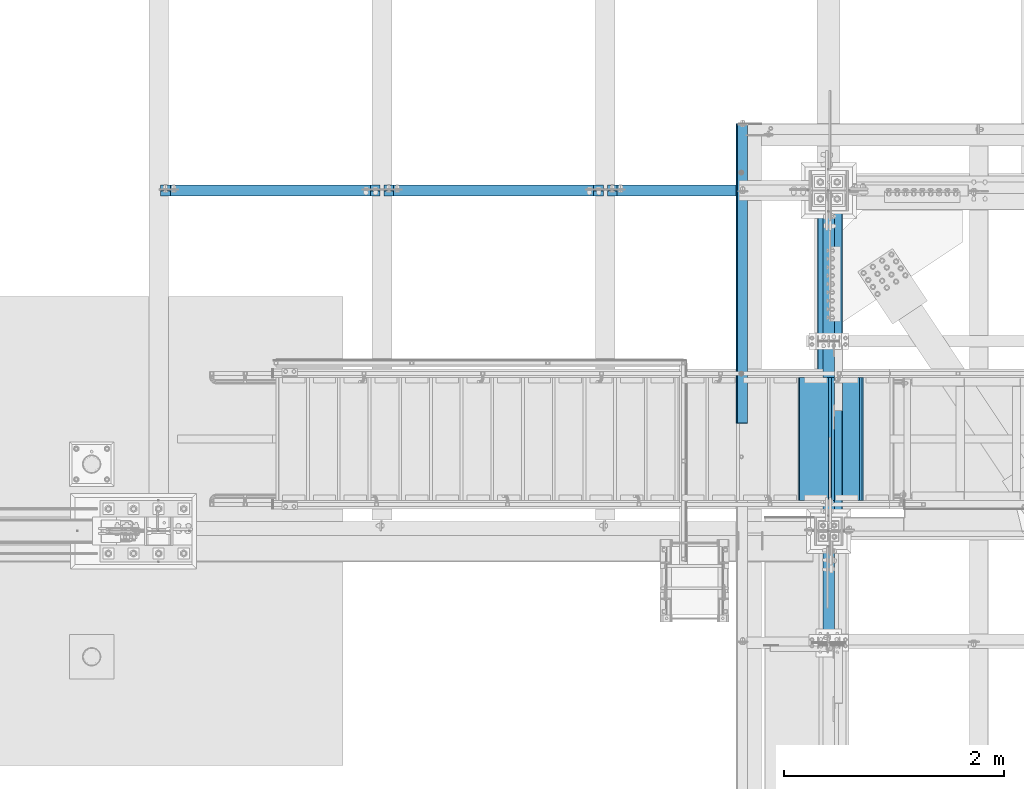
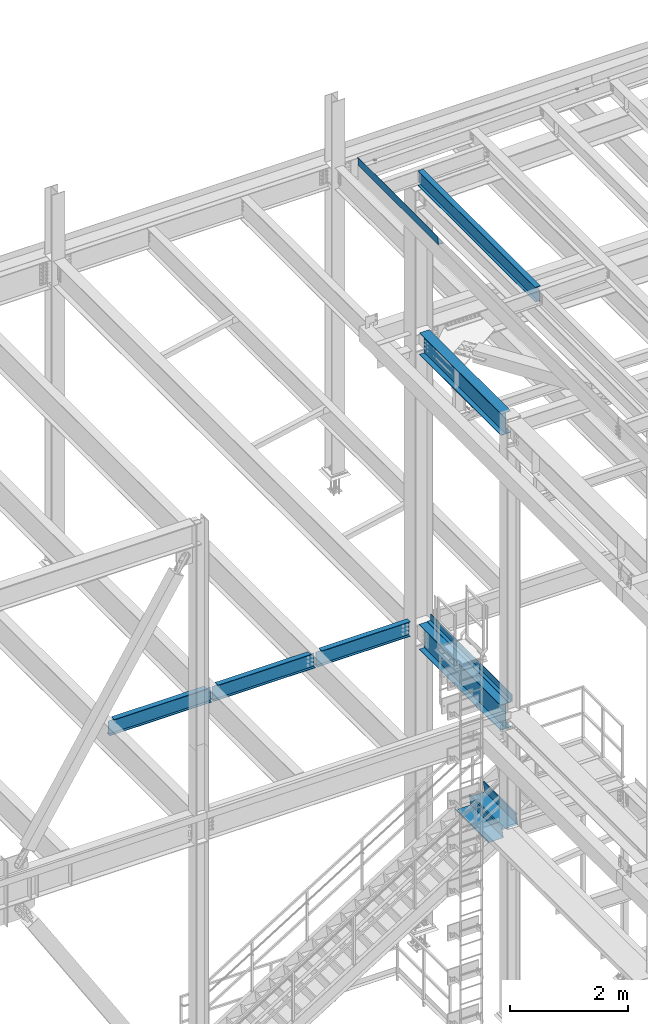
# One storey, part 1885 of 3843: 10 beams, 8 elements without a shape of their own.
"""IFC2X3 building model written with IfcOpenShell, lengths in millimetres."""

from ifc_helpers import new_model, si_unit, frame, origin_with_axes, place, context, subcontext, project, spatial, faceted_brep, material, type_object, element, aggregate, save


model = new_model("IFC2X3")

# Units and contexts
model_context = context("Model", 3, precision=1e-05, world=origin_with_axes())
body_context = subcontext(model_context, "Body", "Model", "MODEL_VIEW")
ifc_project = project(units=[si_unit("LENGTHUNIT", "METRE", prefix="MILLI"), si_unit("AREAUNIT", "SQUARE_METRE"), si_unit("VOLUMEUNIT", "CUBIC_METRE"), si_unit("MASSUNIT", "GRAM", prefix="KILO"), si_unit("TIMEUNIT", "SECOND"), si_unit("PLANEANGLEUNIT", "RADIAN"), si_unit("SOLIDANGLEUNIT", "STERADIAN"), si_unit("THERMODYNAMICTEMPERATUREUNIT", "DEGREE_CELSIUS"), si_unit("LUMINOUSINTENSITYUNIT", "LUMEN")], contexts=[model_context])

# Site, building, storey
site_placement = place(None, origin_with_axes())
site = spatial("IfcSite", under=ifc_project, at=site_placement, CompositionType="ELEMENT")
building_placement = place(site_placement, origin_with_axes())
building = spatial("IfcBuilding", under=site, at=building_placement, Name="Undefined", CompositionType="ELEMENT")
storey_placement = place(building_placement, origin_with_axes())
storey = spatial("IfcBuildingStorey", under=building, at=storey_placement, Name="Undefined", CompositionType="ELEMENT", Elevation=0.0)

# Assembly, beam
assembly_1_placement = place(storey_placement, origin_with_axes())
assembly_1 = element("IfcElementAssembly", 1, at=assembly_1_placement, inside=storey, Name="BEAM", AssemblyPlace="NOTDEFINED", PredefinedType="RIGID_FRAME")
ifc_material_1 = material(Name="STEEL/A36")
beam_type_1 = type_object("IfcBeamType", PredefinedType="NOTDEFINED")
beam_1_placement = place(assembly_1_placement, frame((35839.3101110584, 91460.6375000001, 45717.1843160679), z_axis=(0.0, -1.0, 0.0), x_axis=(-0.999776270257024, 0.0, -0.0211520550054595)))
beam_1 = element("IfcBeam", 2, at=beam_1_placement, type_object=beam_type_1, material=ifc_material_1, Name="BENT_PLATE", context=body_context, shape_type="Brep", body=[
    faceted_brep([(95.2499999981301, -3.17499999995925, 1360.48750004773), (98.4249999510357, -4.77521098218858e-08, 1363.66250000001), (7.27595761418343e-12, -4.77957655675709e-08, 1363.66250000001), (0.0, -3.17499999999563, 1360.48750004772), (95.249999998945, -161.924999996852, 1360.48750004773), (98.4249999518506, -161.924999996845, 1363.66250000001), (0.0, -3.17499999999563, -1363.66250000001), (95.2499999981301, -3.17499999995925, -1363.66250000001), (7.27595761418343e-12, 3.17499999998836, 1363.66250000001), (7.27595761418343e-12, 3.17499999998836, -1363.66250000001), (101.5999999981, 3.17500000003201, 1363.66250000001), (101.5999999981, 3.17500000003201, -1363.66250000001), (101.599999998929, -161.924999996831, 1363.66250000001), (101.599999998929, -161.924999996831, -1363.66250000001), (95.249999998945, -161.924999996852, -1363.66250000001)], [[[0, 1, 2, 3]], [[4, 5, 1, 0]], [[6, 7, 0, 3]], [[8, 9, 6, 3, 2]], [[9, 8, 10, 11]], [[11, 10, 12, 13]], [[5, 12, 10, 8, 2, 1]], [[7, 14, 4, 0]], [[7, 6, 9, 11, 13, 14]], [[14, 13, 12, 5, 4]]]),
])
aggregate(assembly_1, [beam_1])

# Assembly, beams
assembly_2_placement = place(storey_placement, origin_with_axes())
assembly_2 = element("IfcElementAssembly", 3, at=assembly_2_placement, inside=storey, Name="STAIR", AssemblyPlace="NOTDEFINED", PredefinedType="RIGID_FRAME")
ifc_material_2 = material(Name="STEEL/ASTM A1011")
beam_type_2 = type_object("IfcBeamType", PredefinedType="NOTDEFINED")
beam_2_placement = place(assembly_2_placement, frame((36880.8000000271, 89954.1000000435, 33961.8410714329), z_axis=(0.0, -1.0, 0.0), x_axis=(-1.0, 0.0, 0.0)))
beam_2 = element("IfcBeam", 4, at=beam_2_placement, type_object=beam_type_2, material=ifc_material_2, Name="TREAD", context=body_context, shape_type="Brep", body=[
    faceted_brep([(0.0, -1.58750000000146, -558.799999999999), (0.0, -1.58750000000146, 558.799999999999), (0.0, 1.58750000000146, 558.799999999999), (0.0, 1.58750000000146, -558.799999999999), (21.7283948539116, 1.58750000000146, 558.800000000003), (21.7283948539116, 1.58750000000146, -558.800000000003), (25.3999999999942, -1.58750000000146, -558.799999999999), (25.3999999999942, -1.58750000000146, 558.799999999999), (-11.0799384794227, 226.55892857143, 558.800000000003), (-11.0799384794227, 226.55892857143, -558.800000000003), (-7.40833333332557, 223.383928571428, -558.800000000003), (-7.40833333332557, 223.383928571428, 558.800000000003), (293.720061520566, 226.55892857143, 558.800000000003), (293.720061520566, 226.55892857143, -558.800000000003), (290.974498041134, 223.383928571428, -558.800000000003), (290.974498041134, 223.383928571428, 558.800000000003), (299.614357882056, 186.140896378427, 558.800000000003), (299.614357882056, 186.140896378427, -558.800000000003), (296.472590667174, 185.682721992918, 558.800000000003), (296.472590667174, 185.682721992918, -558.800000000003)], [[[0, 1, 2, 3]], [[3, 2, 4, 5]], [[1, 0, 6, 7]], [[5, 4, 8, 9]], [[7, 6, 10, 11]], [[9, 8, 12, 13]], [[11, 10, 14, 15]], [[13, 12, 16, 17]], [[12, 8, 4, 2, 1, 7, 11, 15, 18, 16]], [[15, 14, 19, 18]], [[14, 10, 6, 0, 3, 5, 9, 13, 17, 19]], [[18, 19, 17, 16]]]),
])
beam_3_placement = place(assembly_2_placement, frame((36601.4000000271, 89954.1000000435, 33787.6696428615), z_axis=(0.0, -1.0, 0.0), x_axis=(-1.0, 0.0, 0.0)))
beam_3 = element("IfcBeam", 5, at=beam_3_placement, type_object=beam_type_2, material=ifc_material_2, Name="TREAD", context=body_context, shape_type="Brep", body=[
    faceted_brep([(0.0, -1.58750000000146, -558.799999999999), (0.0, -1.58750000000146, 558.799999999999), (0.0, 1.58750000000146, 558.799999999999), (0.0, 1.58750000000146, -558.799999999999), (21.7283948539116, 1.58750000000146, 558.800000000003), (21.7283948539116, 1.58750000000146, -558.800000000003), (25.3999999999942, -1.58750000000146, -558.799999999999), (25.3999999999942, -1.58750000000146, 558.799999999999), (-11.0799384794227, 226.55892857143, 558.800000000003), (-11.0799384794227, 226.55892857143, -558.800000000003), (-7.40833333332557, 223.383928571428, -558.800000000003), (-7.40833333332557, 223.383928571428, 558.800000000003), (293.720061520566, 226.55892857143, 558.800000000003), (293.720061520566, 226.55892857143, -558.800000000003), (290.974498041134, 223.383928571428, -558.800000000003), (290.974498041134, 223.383928571428, 558.800000000003), (299.614357882056, 186.140896378427, 558.800000000003), (299.614357882056, 186.140896378427, -558.800000000003), (296.472590667174, 185.682721992918, 558.800000000003), (296.472590667174, 185.682721992918, -558.800000000003)], [[[0, 1, 2, 3]], [[3, 2, 4, 5]], [[1, 0, 6, 7]], [[5, 4, 8, 9]], [[7, 6, 10, 11]], [[9, 8, 12, 13]], [[11, 10, 14, 15]], [[13, 12, 16, 17]], [[12, 8, 4, 2, 1, 7, 11, 15, 18, 16]], [[15, 14, 19, 18]], [[14, 10, 6, 0, 3, 5, 9, 13, 17, 19]], [[18, 19, 17, 16]]]),
])
aggregate(assembly_2, [beam_2, beam_3])

# Assembly, beam
assembly_3_placement = place(storey_placement, origin_with_axes())
assembly_3 = element("IfcElementAssembly", 6, at=assembly_3_placement, inside=storey, Name="BEAM", AssemblyPlace="NOTDEFINED", PredefinedType="RIGID_FRAME")
ifc_material_3 = material(Name="STEEL/A992")
beam_type_3 = type_object("IfcBeamType", Name="W12X19", PredefinedType="NOTDEFINED")
beam_4_placement = place(assembly_3_placement, frame((36576.0000000053, 88099.9, 45575.6071293695), z_axis=(0.0, 0.0, 1.0), x_axis=(0.0, 1.0, 0.0)))
beam_4 = element("IfcBeam", 7, at=beam_4_placement, type_object=beam_type_3, material=ifc_material_3, Name="BEAM", ObjectType="W12X19", context=body_context, shape_type="Brep", body=[
    faceted_brep([(4048.125, -3.17500000000291, -144.462500000001), (4048.125, -50.8000000000029, -144.462500000001), (4048.125, -50.8000000000029, -153.987500000003), (4048.125, 50.8000000000029, -153.987500000003), (4048.125, 50.8000000000029, -144.462500000001), (4048.125, 3.17500000000291, -144.462500000001), (4048.125, 3.17500000000291, -141.287499808233), (4048.125, -3.17500000000291, -141.287499808233), (4049.09172992258, 3.17500000000291, -136.427420290187), (4049.09172992258, -3.17500000000291, -136.427420290187), (4051.84474382307, 3.17500000000291, -132.307243822033), (4051.84474382307, -3.17500000000291, -132.307243822033), (4055.96492029123, 3.17500000000291, -129.554229921559), (4055.96492029123, -3.17500000000291, -129.554229921559), (4060.82499980927, 3.17500000000291, -128.587499998968), (4060.82499980927, -3.17500000000291, -128.587499998968), (4098.925, -3.17500000000291, -128.587499998968), (4098.925, 3.17500000000291, -128.587499998968), (4048.125, 50.8000000000029, 144.462500000001), (4048.125, 3.17500000000291, 144.462500000001), (66.6750000000175, 3.17500000000291, 144.462500000001), (66.6750000000175, 50.8000000000029, 144.462500000001), (66.6750000000175, -3.17500000000291, -141.287499808226), (66.6750000000175, 3.17500000000291, -141.287499808226), (66.6750000000175, 3.17500000000291, -144.462500000001), (66.6750000000175, 50.8000000000029, -144.462500000001), (66.6750000000175, 50.8000000000029, -153.987500000003), (66.6750000000175, -50.8000000000029, -153.987500000003), (66.6750000000175, -50.8000000000029, -144.462500000001), (66.6750000000175, -3.17500000000291, -144.462500000001), (65.7082700774336, -3.17500000000291, -136.42742029018), (65.7082700774336, 3.17500000000291, -136.42742029018), (62.9552561769524, -3.17500000000291, -132.307243822026), (62.9552561769524, 3.17500000000291, -132.307243822026), (58.8350797087915, -3.17500000000291, -129.554229921552), (58.8350797087915, 3.17500000000291, -129.554229921552), (53.9750001907523, -3.17500000000291, -128.587499998961), (53.9750001907523, 3.17500000000291, -128.587499998961), (15.8750000000146, -3.17500000000291, -128.587499998961), (15.8750000000146, 3.17500000000291, -128.587499998961), (15.8750000000146, -3.17500000000291, 128.587500001042), (15.8750000000146, 3.17500000000291, 128.587500001042), (15.8750000000146, 3.17500000000291, 115.887500001612), (15.8750000000146, 3.17500000000291, -114.712499998386), (53.9750001907523, -3.17500000000291, 128.587500001042), (53.9750001907523, 3.17500000000291, 128.587500001042), (58.8350797087915, -3.17500000000291, 129.554229923633), (58.8350797087915, 3.17500000000291, 129.554229923633), (62.9552561769524, -3.17500000000291, 132.307243824107), (62.9552561769524, 3.17500000000291, 132.307243824107), (65.7082700774336, -3.17500000000291, 136.427420292261), (65.7082700774336, 3.17500000000291, 136.427420292261), (66.6750000000175, -3.17500000000291, 141.287499810307), (66.6750000000175, 3.17500000000291, 141.287499810307), (66.6750000000175, -50.8000000000029, 153.987500000003), (66.6750000000175, 50.8000000000029, 153.987500000003), (66.6750000000175, -3.17500000000291, 144.462500000001), (66.6750000000175, -50.8000000000029, 144.462500000001), (4048.125, -3.17500000000291, 144.462500000001), (4048.125, -50.8000000000029, 144.462500000001), (4048.125, -50.8000000000029, 153.987500000003), (4048.125, 50.8000000000029, 153.987500000003), (4048.125, -3.17500000000291, 141.2874998103), (4048.125, 3.17500000000291, 141.2874998103), (4049.09172992258, -3.17500000000291, 136.427420292253), (4049.09172992258, 3.17500000000291, 136.427420292253), (4051.84474382307, -3.17500000000291, 132.3072438241), (4051.84474382307, 3.17500000000291, 132.3072438241), (4055.96492029123, -3.17500000000291, 129.554229923626), (4055.96492029123, 3.17500000000291, 129.554229923626), (4060.82499980927, -3.17500000000291, 128.587500001035), (4060.82499980927, 3.17500000000291, 128.587500001035), (4098.925, -3.17500000000291, 128.587500001035), (4098.925, 3.17500000000291, 128.587500001035), (4098.925, 3.17500000000291, -114.712499998452), (4098.925, 3.17500000000291, 115.887500001547)], [[[0, 1, 2, 3, 4, 5, 6, 7]], [[7, 6, 8, 9]], [[9, 8, 10, 11]], [[11, 10, 12, 13]], [[13, 12, 14, 15]], [[16, 15, 14, 17]], [[18, 19, 20, 21]], [[22, 23, 24, 25, 26, 27, 28, 29]], [[30, 31, 23, 22]], [[32, 33, 31, 30]], [[34, 35, 33, 32]], [[36, 37, 35, 34]], [[38, 39, 37, 36]], [[40, 41, 42, 43, 39, 38]], [[44, 45, 41, 40]], [[46, 47, 45, 44]], [[48, 49, 47, 46]], [[50, 51, 49, 48]], [[52, 53, 51, 50]], [[54, 55, 21, 20, 53, 52, 56, 57]], [[58, 59, 57, 56]], [[59, 60, 54, 57]], [[60, 61, 55, 54]], [[61, 18, 21, 55]], [[60, 59, 58, 62, 63, 19, 18, 61]], [[64, 65, 63, 62]], [[66, 67, 65, 64]], [[68, 69, 67, 66]], [[70, 71, 69, 68]], [[72, 73, 71, 70]], [[74, 75, 73, 72, 16, 17]], [[33, 35, 37, 39, 43, 42, 41, 45, 47, 49, 51, 53, 20, 19, 63, 65, 67, 69, 71, 73, 75, 74, 17, 14, 12, 10, 8, 6, 5, 24, 23, 31]], [[5, 4, 25, 24]], [[4, 3, 26, 25]], [[3, 2, 27, 26]], [[2, 1, 28, 27]], [[1, 0, 29, 28]], [[0, 7, 9, 11, 13, 15, 16, 72, 70, 68, 66, 64, 62, 58, 56, 52, 50, 48, 46, 44, 40, 38, 36, 34, 32, 30, 22, 29]]]),
])
aggregate(assembly_3, [beam_4])

assembly_4_placement = place(storey_placement, origin_with_axes())
assembly_4 = element("IfcElementAssembly", 8, at=assembly_4_placement, inside=storey, Name="BEAM", AssemblyPlace="NOTDEFINED", PredefinedType="RIGID_FRAME")
beam_5_placement = place(assembly_4_placement, frame((30480.0, 92214.7, 36282.3125), z_axis=(0.0, 0.0, 1.0), x_axis=(1.0, 0.0, 0.0)))
beam_5 = element("IfcBeam", 9, at=beam_5_placement, type_object=beam_type_3, material=ifc_material_3, Name="BEAM", ObjectType="W12X19", context=body_context, shape_type="Brep", body=[
    faceted_brep([(1925.6375, -50.8000000000029, 153.987499991192), (1925.6375, -50.8000000000029, 144.462500000001), (1925.6375, -3.17500000000291, 144.462500000001), (1925.6375, -3.17500000000291, 141.287499809267), (1925.6375, 3.17500000000291, 141.287499809267), (1925.6375, 3.17500000000291, 144.462500000001), (1925.6375, 50.8000000000029, 144.462500000001), (1925.6375, 50.8000000000029, 153.987500000003), (1926.60422992258, -3.17500000000291, 136.42742029122), (1926.60422992258, 3.17500000000291, 136.42742029122), (1929.35724382306, -3.17500000000291, 132.307243823067), (1929.35724382306, 3.17500000000291, 132.307243823067), (1933.47742029122, -3.17500000000291, 129.554229922593), (1933.47742029122, 3.17500000000291, 129.554229922593), (1938.33749980926, -3.17500000000291, 128.587500000001), (1938.33749980926, 3.17500000000291, 128.587500000001), (2014.5375, -3.17500000000291, 128.587500000001), (2014.5375, 3.17500000000291, 128.587500000001), (106.362500000003, -50.8000000000029, 153.987499811003), (106.362500000003, 50.8000000000029, 153.987500000003), (106.362500000003, 50.8000000000029, 144.462500000001), (106.362500000003, 3.17500000000291, 144.462500000001), (106.362500000003, 3.17500000000291, 141.287499809267), (106.362500000003, -3.17500000000291, 141.287499809267), (106.362500000003, -3.17500000000291, 144.462500000001), (106.362500000003, -50.8000000000029, 144.462500000001), (105.395770077415, 3.17500000000291, 136.42742029122), (105.395770077415, -3.17500000000291, 136.42742029122), (102.642756176938, 3.17500000000291, 132.307243823067), (102.642756176938, -3.17500000000291, 132.307243823067), (98.5225797087842, 3.17500000000291, 129.554229922593), (98.5225797087842, -3.17500000000291, 129.554229922593), (93.6625001907378, 3.17500000000291, 128.587500000001), (93.6625001907378, -3.17500000000291, 128.587500000001), (17.4625000000015, 3.17500000000291, 128.587500000001), (17.4625000000015, -3.17500000000291, 128.587500000001), (17.4624999999942, 3.17500000000291, 122.237500000003), (17.4625000000015, 3.17500000000291, -121.062500000218), (17.4624999999942, 3.17500000000291, -144.462500000001), (17.4624999999942, 50.8000000000029, -144.462500000001), (17.4624999999942, 50.8000000000029, -153.987500000003), (17.4624999999942, -50.8000000000029, -153.987500000003), (17.4624999999942, -50.8000000000029, -144.462500000001), (17.4624999999942, -3.17500000000291, -144.462500000001), (2014.5375, 3.17500000000291, -144.462500000001), (2014.5375, 50.8000000000029, -144.462500000001), (2014.5375, 50.8000000000029, -153.987500000003), (2014.5375, -50.8000000000029, -153.987500000003), (2014.5375, -50.8000000000029, -144.462500000001), (2014.5375, -3.17500000000291, -144.462500000001), (2014.5375, 3.17500000000291, 122.237500000003), (2014.5375, 3.17500000000291, -121.0625)], [[[0, 1, 2, 3, 4, 5, 6, 7]], [[8, 9, 4, 3]], [[10, 11, 9, 8]], [[12, 13, 11, 10]], [[14, 15, 13, 12]], [[16, 17, 15, 14]], [[18, 19, 20, 21, 22, 23, 24, 25]], [[23, 22, 26, 27]], [[27, 26, 28, 29]], [[29, 28, 30, 31]], [[31, 30, 32, 33]], [[33, 32, 34, 35]], [[36, 37, 38, 39, 40, 41, 42, 43, 35, 34]], [[39, 38, 44, 45]], [[40, 39, 45, 46]], [[41, 40, 46, 47]], [[42, 41, 47, 48]], [[43, 42, 48, 49]], [[12, 10, 8, 3, 2, 24, 23, 27, 29, 31, 33, 35, 43, 49, 16, 14]], [[25, 24, 2, 1]], [[18, 25, 1, 0]], [[19, 18, 0, 7]], [[20, 19, 7, 6]], [[21, 20, 6, 5]], [[50, 51, 44, 38, 37, 36, 34, 32, 30, 28, 26, 22, 21, 5, 4, 9, 11, 13, 15, 17]], [[49, 48, 47, 46, 45, 44, 51, 50, 17, 16]]]),
])
aggregate(assembly_4, [beam_5])

assembly_5_placement = place(storey_placement, origin_with_axes())
assembly_5 = element("IfcElementAssembly", 10, at=assembly_5_placement, inside=storey, Name="BEAM", AssemblyPlace="NOTDEFINED", PredefinedType="RIGID_FRAME")
beam_6_placement = place(assembly_5_placement, frame((32512.0, 92214.7, 36282.3125), z_axis=(0.0, 0.0, 1.0), x_axis=(1.0, 0.0, 0.0)))
beam_6 = element("IfcBeam", 11, at=beam_6_placement, type_object=beam_type_3, material=ifc_material_3, Name="BEAM", ObjectType="W12X19", context=body_context, shape_type="Brep", body=[
    faceted_brep([(1925.6375, -50.8000000000029, 153.987499991192), (1925.6375, -50.8000000000029, 144.462500000001), (1925.6375, -3.17500000000291, 144.462500000001), (1925.6375, -3.17500000000291, 141.287499809267), (1925.6375, 3.17500000000291, 141.287499809267), (1925.6375, 3.17500000000291, 144.462500000001), (1925.6375, 50.8000000000029, 144.462500000001), (1925.6375, 50.8000000000029, 153.987500000003), (1926.60422992258, -3.17500000000291, 136.42742029122), (1926.60422992258, 3.17500000000291, 136.42742029122), (1929.35724382306, -3.17500000000291, 132.307243823067), (1929.35724382306, 3.17500000000291, 132.307243823067), (1933.47742029122, -3.17500000000291, 129.554229922593), (1933.47742029122, 3.17500000000291, 129.554229922593), (1938.33749980926, -3.17500000000291, 128.587500000001), (1938.33749980926, 3.17500000000291, 128.587500000001), (2014.5375, -3.17500000000291, 128.587500000001), (2014.5375, 3.17500000000291, 128.587500000001), (106.362500000003, -50.8000000000029, 153.987499811003), (106.362500000003, 50.8000000000029, 153.987500000003), (106.362500000003, 50.8000000000029, 144.462500000001), (106.362500000003, 3.17500000000291, 144.462500000001), (106.362500000003, 3.17500000000291, 141.287499809267), (106.362500000003, -3.17500000000291, 141.287499809267), (106.362500000003, -3.17500000000291, 144.462500000001), (106.362500000003, -50.8000000000029, 144.462500000001), (105.395770077415, 3.17500000000291, 136.42742029122), (105.395770077415, -3.17500000000291, 136.42742029122), (102.642756176938, 3.17500000000291, 132.307243823067), (102.642756176938, -3.17500000000291, 132.307243823067), (98.5225797087842, 3.17500000000291, 129.554229922593), (98.5225797087842, -3.17500000000291, 129.554229922593), (93.6625001907378, 3.17500000000291, 128.587500000001), (93.6625001907378, -3.17500000000291, 128.587500000001), (17.4625000000015, 3.17500000000291, 128.587500000001), (17.4625000000015, -3.17500000000291, 128.587500000001), (17.4624999999942, 3.17500000000291, 122.237500000003), (17.4625000000015, 3.17500000000291, -121.062500000218), (17.4624999999942, 3.17500000000291, -144.462500000001), (17.4624999999942, 50.8000000000029, -144.462500000001), (17.4624999999942, 50.8000000000029, -153.987500000003), (17.4624999999942, -50.8000000000029, -153.987500000003), (17.4624999999942, -50.8000000000029, -144.462500000001), (17.4624999999942, -3.17500000000291, -144.462500000001), (2014.5375, 3.17500000000291, -144.462500000001), (2014.5375, 50.8000000000029, -144.462500000001), (2014.5375, 50.8000000000029, -153.987500000003), (2014.5375, -50.8000000000029, -153.987500000003), (2014.5375, -50.8000000000029, -144.462500000001), (2014.5375, -3.17500000000291, -144.462500000001), (2014.5375, 3.17500000000291, 122.237500000003), (2014.5375, 3.17500000000291, -121.0625)], [[[0, 1, 2, 3, 4, 5, 6, 7]], [[8, 9, 4, 3]], [[10, 11, 9, 8]], [[12, 13, 11, 10]], [[14, 15, 13, 12]], [[16, 17, 15, 14]], [[18, 19, 20, 21, 22, 23, 24, 25]], [[23, 22, 26, 27]], [[27, 26, 28, 29]], [[29, 28, 30, 31]], [[31, 30, 32, 33]], [[33, 32, 34, 35]], [[36, 37, 38, 39, 40, 41, 42, 43, 35, 34]], [[39, 38, 44, 45]], [[40, 39, 45, 46]], [[41, 40, 46, 47]], [[42, 41, 47, 48]], [[43, 42, 48, 49]], [[12, 10, 8, 3, 2, 24, 23, 27, 29, 31, 33, 35, 43, 49, 16, 14]], [[25, 24, 2, 1]], [[18, 25, 1, 0]], [[19, 18, 0, 7]], [[20, 19, 7, 6]], [[21, 20, 6, 5]], [[50, 51, 44, 38, 37, 36, 34, 32, 30, 28, 26, 22, 21, 5, 4, 9, 11, 13, 15, 17]], [[49, 48, 47, 46, 45, 44, 51, 50, 17, 16]]]),
])
aggregate(assembly_5, [beam_6])

assembly_6_placement = place(storey_placement, origin_with_axes())
assembly_6 = element("IfcElementAssembly", 12, at=assembly_6_placement, inside=storey, Name="BEAM", AssemblyPlace="NOTDEFINED", PredefinedType="RIGID_FRAME")
beam_7_placement = place(assembly_6_placement, frame((34544.0, 92214.7, 36282.3125), z_axis=(0.0, 0.0, 1.0), x_axis=(1.0, 0.0, 0.0)))
beam_7 = element("IfcBeam", 13, at=beam_7_placement, type_object=beam_type_3, material=ifc_material_3, Name="BEAM", ObjectType="W12X19", context=body_context, shape_type="Brep", body=[
    faceted_brep([(17.4624999999942, -3.17500000000291, -144.462500000001), (17.4624999999942, -50.8000000000029, -144.462500000001), (1841.5, -50.8000000000029, -144.462500000001), (1841.5, -3.17500000000291, -144.462500000001), (17.4624999999942, -50.8000000000029, -153.987500000003), (1841.5, -50.8000000000029, -153.987500000003), (17.4624999999942, 50.8000000000029, -153.987500000003), (1841.5, 50.8000000000029, -153.987500000003), (17.4624999999942, 50.8000000000029, -144.462500000001), (1841.5, 50.8000000000029, -144.462500000001), (1841.5, 3.17500000000291, -144.462500000001), (1841.5, 3.17500000000291, 144.462500000001), (1841.5, 50.8000000000029, 144.462500000001), (1841.5, 50.8000000000029, 153.987500000003), (1841.5, -50.8000000000029, 153.987500000003), (1841.5, -50.8000000000029, 144.462500000001), (1841.5, -3.17500000000291, 144.462500000001), (17.4624999999942, 3.17500000000291, -144.462500000001), (98.5225797087842, -3.17500000000291, 129.554229922593), (98.5225797087842, 3.17500000000291, 129.554229922593), (93.6625001907378, 3.17500000000291, 128.587500000001), (93.6625001907378, -3.17500000000291, 128.587500000001), (102.642756176938, -3.17500000000291, 132.307243823067), (102.642756176938, 3.17500000000291, 132.307243823067), (105.395770077415, -3.17500000000291, 136.42742029122), (105.395770077415, 3.17500000000291, 136.42742029122), (106.362500000003, -3.17500000000291, 141.287499809267), (106.362500000003, 3.17500000000291, 141.287499809267), (17.4625000000015, 3.17500000000291, -121.062500000218), (17.4624999999942, 3.17500000000291, 122.237500000003), (17.4625000000015, 3.17500000000291, 128.587500000001), (106.362500000003, 3.17500000000291, 144.462500000001), (106.362500000003, 50.8000000000029, 144.462500000001), (106.362500000003, 50.8000000000029, 153.987500000003), (106.362500000003, -50.8000000000029, 153.987499811003), (106.362500000003, -50.8000000000029, 144.462500000001), (106.362500000003, -3.17500000000291, 144.462500000001), (17.4625000000015, -3.17500000000291, 128.587500000001)], [[[0, 1, 2, 3]], [[1, 4, 5, 2]], [[4, 6, 7, 5]], [[6, 8, 9, 7]], [[10, 11, 12, 13, 14, 15, 16, 3, 2, 5, 7, 9]], [[8, 17, 10, 9]], [[18, 19, 20, 21]], [[22, 23, 19, 18]], [[24, 25, 23, 22]], [[26, 27, 25, 24]], [[11, 10, 17, 28, 29, 30, 20, 19, 23, 25, 27, 31]], [[12, 11, 31, 32]], [[13, 12, 32, 33]], [[14, 13, 33, 34]], [[15, 14, 34, 35]], [[16, 15, 35, 36]], [[34, 33, 32, 31, 27, 26, 36, 35]], [[24, 22, 18, 21, 37, 0, 3, 16, 36, 26]], [[29, 28, 17, 8, 6, 4, 1, 0, 37, 30]], [[21, 20, 30, 37]]]),
])
aggregate(assembly_6, [beam_7])

assembly_7_placement = place(storey_placement, origin_with_axes())
assembly_7 = element("IfcElementAssembly", 14, at=assembly_7_placement, inside=storey, Name="BEAM", AssemblyPlace="NOTDEFINED", PredefinedType="RIGID_FRAME")
beam_type_4 = type_object("IfcBeamType", PredefinedType="NOTDEFINED")
beam_8_placement = place(assembly_7_placement, frame((36628.388, 90637.519, 36439.475), z_axis=(0.0, -1.0, 0.0), x_axis=(1.0, 0.0, 0.0)))
beam_8 = element("IfcBeam", 15, at=beam_8_placement, type_object=beam_type_4, material=ifc_material_1, Name="BENT_PLATE", context=body_context, shape_type="Brep", body=[
    faceted_brep([(0.0, -3.17500000000291, -1380.3315), (0.0, -3.17500000000291, 1380.3315), (0.0, 3.17500000000291, 1380.3315), (0.0, 3.17500000000291, -1380.3315), (68.2619995117129, 3.17500000000291, 1380.3315), (68.2619995117129, 3.17500000000291, -1380.3315), (74.6119995117188, -3.17500000000291, -1380.3315), (74.6119995117188, -3.17500000000291, 1380.3315), (68.2619995117129, 136.524996948239, 1380.3315), (68.2619995117129, 136.524996948239, -1380.3315), (74.6119995117188, 136.524996948239, 1380.3315), (74.6119995117188, 136.524996948239, -1380.3315)], [[[0, 1, 2, 3]], [[3, 2, 4, 5]], [[1, 0, 6, 7]], [[5, 4, 8, 9]], [[4, 2, 1, 7, 10, 8]], [[7, 6, 11, 10]], [[6, 0, 3, 5, 9, 11]], [[10, 11, 9, 8]]]),
])

assembly_8_placement = place(storey_placement, origin_with_axes())
assembly_8 = element("IfcElementAssembly", 16, at=assembly_8_placement, inside=storey, Name="BEAM", AssemblyPlace="NOTDEFINED", PredefinedType="RIGID_FRAME")
beam_type_5 = type_object("IfcBeamType", Name="W18X50", PredefinedType="NOTDEFINED")
beam_9_placement = place(assembly_8_placement, frame((36576.0, 89115.9, 42240.2), z_axis=(0.0, 0.0, 1.0), x_axis=(0.0, 1.0, 0.0)))
beam_9 = element("IfcBeam", 17, at=beam_9_placement, type_object=beam_type_5, material=ifc_material_3, Name="BEAM", ObjectType="W18X50", context=body_context, shape_type="Brep", body=[
    faceted_brep([(141.287500000006, -95.25, -228.599999999999), (141.287500000006, 95.25, -228.599999999999), (2901.95000000001, 95.25, -228.599999999999), (2901.95000000001, -95.25, -228.599999999999), (141.287500000006, -95.25, -214.3125), (141.287500000006, -4.76249999999709, -214.3125), (141.287500000006, -4.76249999999709, 214.3125), (141.287500000006, -95.25, 214.3125), (141.287500000006, -95.25, 228.599999999999), (141.287500000006, 95.25, 228.599999999999), (141.287500000006, 95.25, 214.3125), (141.287500000006, 4.76249999999709, 214.3125), (141.287500000006, 4.76249999999709, -214.3125), (141.287500000006, 95.25, -214.3125), (2901.95000000001, -95.25, -214.3125), (2901.95000000001, -4.76249999999709, -214.3125), (2901.95000000001, -4.76249999999709, 214.3125), (2901.95000000001, -95.25, 214.3125), (2901.95000000001, -95.25, 228.599999999999), (2901.95000000001, 95.25, 228.599999999999), (2901.95000000001, 95.25, 214.3125), (2901.95000000001, 4.76249999999709, 214.3125), (2901.95000000001, 4.76249999999709, -214.3125), (2901.95000000001, 95.25, -214.3125)], [[[0, 1, 2, 3]], [[0, 4, 5, 6, 7, 8, 9, 10, 11, 12, 13, 1]], [[5, 4, 14, 15]], [[6, 5, 15, 16]], [[7, 6, 16, 17]], [[8, 7, 17, 18]], [[9, 8, 18, 19]], [[10, 9, 19, 20]], [[11, 10, 20, 21]], [[12, 11, 21, 22]], [[13, 12, 22, 23]], [[1, 13, 23, 2]], [[22, 21, 20, 19, 18, 17, 16, 15, 14, 3, 2, 23]], [[4, 0, 3, 14]]]),
])
aggregate(assembly_8, [beam_9])

# Beam
beam_type_6 = type_object("IfcBeamType", Name="W21X48", PredefinedType="NOTDEFINED")
beam_10_placement = place(assembly_7_placement, frame((36576.0, 89115.9, 36174.3625), z_axis=(0.0, 0.0, 1.0), x_axis=(0.0, 1.0, 0.0)))
beam_10 = element("IfcBeam", 18, at=beam_10_placement, type_object=beam_type_6, material=ifc_material_3, Name="BEAM", ObjectType="W21X48", context=body_context, shape_type="Brep", body=[
    faceted_brep([(141.287499999962, 103.1875, -261.9375), (141.287499999962, 103.1875, -250.824999999997), (2901.95000000006, 103.1875, -250.824999999997), (2901.95000000006, 103.1875, -261.9375), (141.287499999962, 4.76249999999709, -250.824999999997), (2901.95000000006, 4.76249999999709, -250.824999999997), (141.287499999962, 4.76249999999709, 250.824999999997), (2901.95000000006, 4.76249999999709, 250.824999999997), (141.287499999962, 103.1875, 250.824999999997), (2901.95000000006, 103.1875, 250.824999999997), (141.287499999962, 103.1875, 261.9375), (2901.95000000006, 103.1875, 261.9375), (141.287499999962, -103.1875, 261.9375), (2901.95000000006, -103.1875, 261.9375), (141.287499999962, -103.1875, 250.824999999997), (2901.95000000006, -103.1875, 250.824999999997), (141.287499999962, -4.76249999999709, 250.824999999997), (2901.95000000006, -4.76249999999709, 250.824999999997), (141.287499999962, -4.76249999999709, -250.824999999997), (2901.95000000006, -4.76249999999709, -250.824999999997), (141.287499999962, -103.1875, -250.824999999997), (2901.95000000006, -103.1875, -250.824999999997), (141.287499999962, -103.1875, -261.9375), (2901.95000000006, -103.1875, -261.9375)], [[[0, 1, 2, 3]], [[1, 4, 5, 2]], [[4, 6, 7, 5]], [[6, 8, 9, 7]], [[8, 10, 11, 9]], [[10, 12, 13, 11]], [[12, 14, 15, 13]], [[14, 16, 17, 15]], [[16, 18, 19, 17]], [[18, 20, 21, 19]], [[20, 22, 23, 21]], [[22, 0, 3, 23]], [[5, 7, 9, 11, 13, 15, 17, 19, 21, 23, 3, 2]], [[22, 20, 18, 16, 14, 12, 10, 8, 6, 4, 1, 0]]]),
])

aggregate(assembly_7, [beam_8, beam_10])

save(model, "model.ifc")
